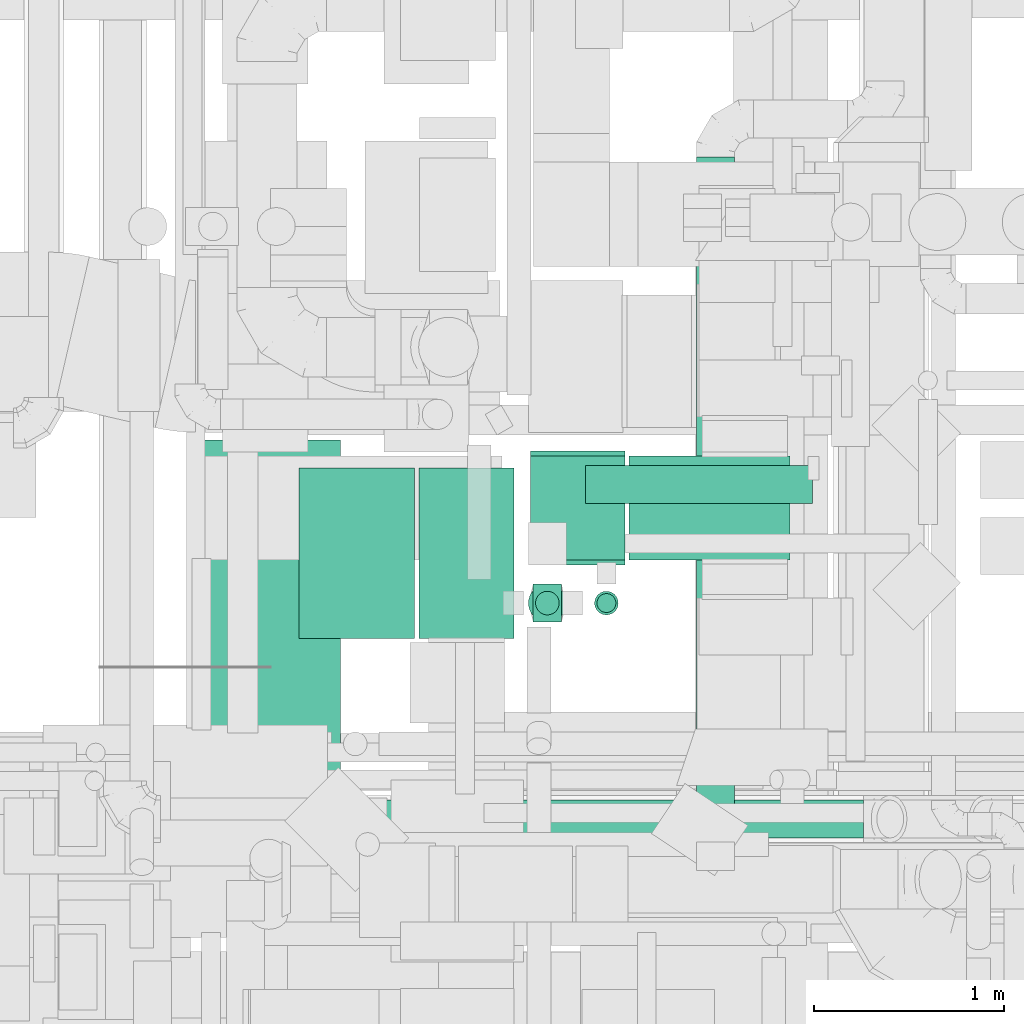
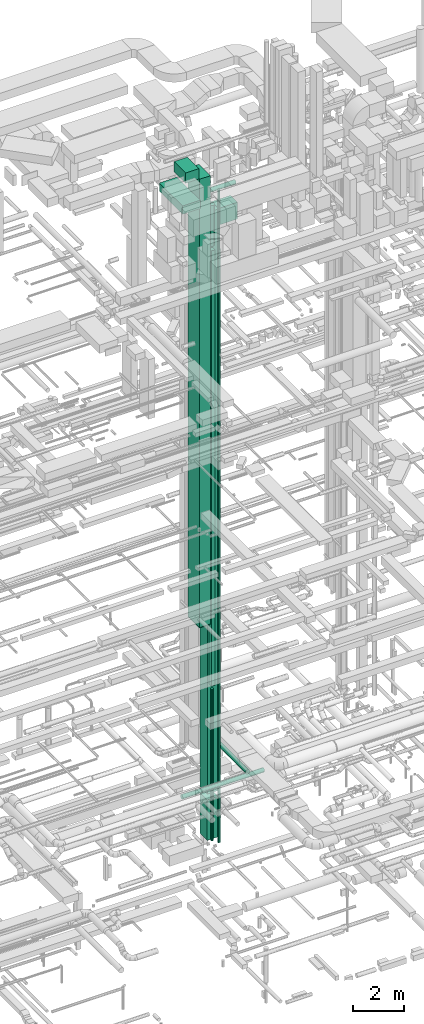
# One storey, part 41 of 337: 14 flow segments, 1 flow fitting.
"""IFC2X3 building model written with IfcOpenShell, lengths in millimetres."""

from ifc_helpers import new_model, entity, si_unit, converted_unit, derived_unit, direction, frame, origin, origin_2d_with_axis, place, context, subcontext, project, spatial, rectangle, circle, extrude, source, transform, mapped, material, type_object, type_shapes, element, save


model = new_model("IFC2X3")

# Units and contexts
model_context = context("Model", 3, precision=0.01, world=origin(), true_north=direction((6.12303176911189e-17, 1.0)))
body_context = subcontext(model_context, "Body", "Model", "MODEL_VIEW")
ifc_project = project(units=[si_unit("LENGTHUNIT", "METRE", prefix="MILLI"), si_unit("AREAUNIT", "SQUARE_METRE"), si_unit("VOLUMEUNIT", "CUBIC_METRE"), converted_unit("PLANEANGLEUNIT", "DEGREE", entity("IfcRatioMeasure", 0.0174532925199433), si_unit("PLANEANGLEUNIT", "RADIAN"), dimensions=[0, 0, 0, 0, 0, 0, 0]), si_unit("MASSUNIT", "GRAM", prefix="KILO"), derived_unit("MASSDENSITYUNIT", [(si_unit("MASSUNIT", "GRAM", prefix="KILO"), 1), (si_unit("LENGTHUNIT", "METRE"), -3)]), derived_unit("MOMENTOFINERTIAUNIT", [(si_unit("LENGTHUNIT", "METRE"), 4)]), si_unit("TIMEUNIT", "SECOND"), si_unit("FREQUENCYUNIT", "HERTZ"), si_unit("THERMODYNAMICTEMPERATUREUNIT", "DEGREE_CELSIUS"), derived_unit("THERMALTRANSMITTANCEUNIT", [(si_unit("MASSUNIT", "GRAM", prefix="KILO"), 1), (si_unit("THERMODYNAMICTEMPERATUREUNIT", "KELVIN"), -1), (si_unit("TIMEUNIT", "SECOND"), -3)]), derived_unit("VOLUMETRICFLOWRATEUNIT", [(si_unit("LENGTHUNIT", "METRE"), 3), (si_unit("TIMEUNIT", "SECOND"), -1)]), derived_unit("MASSFLOWRATEUNIT", [(si_unit("MASSUNIT", "GRAM", prefix="KILO"), 1), (si_unit("TIMEUNIT", "SECOND"), -1)]), derived_unit("ROTATIONALFREQUENCYUNIT", [(si_unit("TIMEUNIT", "SECOND"), -1)]), si_unit("ELECTRICCURRENTUNIT", "AMPERE"), si_unit("ELECTRICVOLTAGEUNIT", "VOLT"), si_unit("POWERUNIT", "WATT"), si_unit("FORCEUNIT", "NEWTON", prefix="KILO"), si_unit("ILLUMINANCEUNIT", "LUX"), si_unit("LUMINOUSFLUXUNIT", "LUMEN"), si_unit("LUMINOUSINTENSITYUNIT", "CANDELA"), derived_unit("USERDEFINED", [(si_unit("MASSUNIT", "GRAM", prefix="KILO"), -1), (si_unit("LENGTHUNIT", "METRE"), -2), (si_unit("TIMEUNIT", "SECOND"), 3), (si_unit("LUMINOUSFLUXUNIT", "LUMEN"), 1)]), derived_unit("LINEARVELOCITYUNIT", [(si_unit("LENGTHUNIT", "METRE"), 1), (si_unit("TIMEUNIT", "SECOND"), -1)]), si_unit("PRESSUREUNIT", "PASCAL"), derived_unit("USERDEFINED", [(si_unit("LENGTHUNIT", "METRE"), -2), (si_unit("MASSUNIT", "GRAM", prefix="KILO"), 1), (si_unit("TIMEUNIT", "SECOND"), -2)]), derived_unit("LINEARFORCEUNIT", [(si_unit("MASSUNIT", "GRAM", prefix="KILO"), 1), (si_unit("LENGTHUNIT", "METRE"), 1), (si_unit("TIMEUNIT", "SECOND"), -2), (si_unit("LENGTHUNIT", "METRE"), -1)]), derived_unit("PLANARFORCEUNIT", [(si_unit("MASSUNIT", "GRAM", prefix="KILO"), 1), (si_unit("LENGTHUNIT", "METRE"), 1), (si_unit("TIMEUNIT", "SECOND"), -2), (si_unit("LENGTHUNIT", "METRE"), -2)])], contexts=[model_context])

# Site, building, storey
site_placement = place(None, origin())
site = spatial("IfcSite", under=ifc_project, at=site_placement, CompositionType="ELEMENT")
building_placement = place(site_placement, origin())
building = spatial("IfcBuilding", under=site, at=building_placement, CompositionType="ELEMENT")
storey_placement = place(building_placement, origin())
storey = spatial("IfcBuildingStorey", under=building, at=storey_placement, CompositionType="ELEMENT", Elevation=0.0)

# Flow segments
duct_segment_type_1 = type_object("IfcDuctSegmentType", PredefinedType="NOTDEFINED")
flow_segment_1_placement = place(storey_placement, frame((44418.87, 10801.83, 9956.03)))
element("IfcFlowSegment", 1, at=flow_segment_1_placement, inside=storey, type_object=duct_segment_type_1, context=body_context, shape_type="SweptSolid", body=[
    extrude(rectangle(XDim=899.999999999999, YDim=499.999999999999, at=origin_2d_with_axis()), frame((250.0, 450.0, 0.0), z_axis=(0.0, 0.0, 1.0), x_axis=(0.0, -1.0, 0.0)), (0.0, 0.0, 1.0), 21478.9659417169),
])
flow_segment_2_placement = place(storey_placement, frame((45020.05, 10888.58, 6880.0)))
element("IfcFlowSegment", 2, at=flow_segment_2_placement, inside=storey, type_object=duct_segment_type_1, context=body_context, shape_type="SweptSolid", body=[
    extrude(rectangle(XDim=150.000000000001, YDim=200.0, at=origin_2d_with_axis()), frame((75.0, 100.0, 0.0)), (0.0, 0.0, 1.0), 20860.0),
])
flow_segment_3_placement = place(storey_placement, frame((43785.45, 10801.83, 31460.0)))
element("IfcFlowSegment", 3, at=flow_segment_3_placement, inside=storey, type_object=duct_segment_type_1, context=body_context, shape_type="SweptSolid", body=[
    extrude(rectangle(XDim=608.426980000926, YDim=900.000000000001, at=origin_2d_with_axis()), frame((304.21, 450.0, 0.0)), (0.0, 0.0, 1.0), 499.999999999999),
])
flow_segment_4_placement = place(storey_placement, frame((45524.94, 11214.6, 28600.0)))
element("IfcFlowSegment", 4, at=flow_segment_4_placement, inside=storey, type_object=duct_segment_type_1, context=body_context, shape_type="SweptSolid", body=[
    extrude(rectangle(XDim=848.580511700843, YDim=550.000000000001, at=origin_2d_with_axis()), frame((424.29, 275.0, 0.0), z_axis=(0.0, 0.0, 1.0), x_axis=(-1.0, 0.0, 0.0)), (0.0, 0.0, 1.0), 800.0),
])
flow_segment_5_placement = place(storey_placement, frame((43202.86, 10023.67, 30650.0)))
element("IfcFlowSegment", 5, at=flow_segment_5_placement, inside=storey, type_object=duct_segment_type_1, context=body_context, shape_type="SweptSolid", body=[
    extrude(rectangle(XDim=1826.18340999988, YDim=800.0, at=origin_2d_with_axis()), frame((400.0, 913.09, 0.0), z_axis=(0.0, 0.0, 1.0), x_axis=(0.0, 1.0, 0.0)), (0.0, 0.0, 1.0), 399.999999999996),
])
flow_segment_6_placement = place(storey_placement, frame((45004.94, 11189.6, 1536.11)))
element("IfcFlowSegment", 6, at=flow_segment_6_placement, inside=storey, type_object=duct_segment_type_1, context=body_context, shape_type="SweptSolid", body=[
    extrude(rectangle(XDim=600.000000000004, YDim=499.999999999999, at=origin_2d_with_axis()), frame((250.0, 300.0, 0.0), z_axis=(0.0, 0.0, 1.0), x_axis=(0.0, -1.0, 0.0)), (0.0, 0.0, 1.0), 27863.8898629147),
])
flow_segment_7_placement = place(storey_placement, frame((45004.94, 11214.6, -700.0)))
element("IfcFlowSegment", 7, at=flow_segment_7_placement, inside=storey, type_object=duct_segment_type_1, context=body_context, shape_type="SweptSolid", body=[
    extrude(rectangle(XDim=500.000000000008, YDim=550.000000000001, at=origin_2d_with_axis()), frame((250.0, 275.0, 0.0)), (0.0, 0.0, 1.0), 1936.1101370854),
])
duct_segment_type_2 = type_object("IfcDuctSegmentType", PredefinedType="NOTDEFINED")
flow_segment_8_placement = place(storey_placement, frame((45030.95, 10924.48, -575.0)))
element("IfcFlowSegment", 8, at=flow_segment_8_placement, inside=storey, type_object=duct_segment_type_2, context=body_context, shape_type="SweptSolid", body=[
    extrude(circle(Radius=62.5, at=origin_2d_with_axis()), frame((64.1, 64.1, 0.0), z_axis=(0.0, 0.0, 1.0), x_axis=(0.0, 1.0, 0.0)), (0.0, 0.0, 1.0), 7255.0),
])
flow_segment_9_placement = place(storey_placement, frame((45342.55, 10924.48, -775.0)))
element("IfcFlowSegment", 9, at=flow_segment_9_placement, inside=storey, type_object=duct_segment_type_2, context=body_context, shape_type="SweptSolid", body=[
    extrude(circle(Radius=62.5, at=origin_2d_with_axis()), frame((64.1, 64.1, 0.0), z_axis=(0.0, 0.0, 1.0), x_axis=(0.0, -1.0, 0.0)), (0.0, 0.0, 1.0), 28420.0),
])
flow_segment_10_placement = place(storey_placement, frame((45295.05, 11513.01, 29998.4)))
element("IfcFlowSegment", 10, at=flow_segment_10_placement, inside=storey, type_object=duct_segment_type_2, context=body_context, shape_type="SweptSolid", body=[
    extrude(circle(Radius=100.0, at=origin_2d_with_axis()), frame((0.0, 101.6, 101.6), z_axis=(1.0, 0.0, 0.0), x_axis=(0.0, 1.0, 0.0)), (0.0, 0.0, 1.0), 1199.42629020623),
])
flow_segment_11_placement = place(storey_placement, frame((44993.45, 10886.98, 27940.0)))
element("IfcFlowSegment", 11, at=flow_segment_11_placement, inside=storey, type_object=duct_segment_type_2, context=body_context, shape_type="SweptSolid", body=[
    extrude(circle(Radius=100.0, at=origin_2d_with_axis()), frame((101.6, 101.6, 0.0), z_axis=(0.0, 0.0, 1.0), x_axis=(-1.0, 0.0, 0.0)), (0.0, 0.0, 1.0), 1960.00000000001),
])
flow_segment_12_placement = place(storey_placement, frame((45355.05, 10936.98, 27670.0)))
element("IfcFlowSegment", 12, at=flow_segment_12_placement, inside=storey, type_object=duct_segment_type_2, context=body_context, shape_type="SweptSolid", body=[
    extrude(circle(Radius=50.0, at=origin_2d_with_axis()), frame((51.6, 51.6, 0.0)), (0.0, 0.0, 1.0), 2833.42267808452),
])
flow_segment_13_placement = place(storey_placement, frame((43055.12, 9748.4, 2798.4)))
element("IfcFlowSegment", 13, at=flow_segment_13_placement, inside=storey, type_object=duct_segment_type_2, context=body_context, shape_type="SweptSolid", body=[
    extrude(circle(Radius=100.0, at=origin_2d_with_axis()), frame((0.0, 101.6, 101.6), z_axis=(1.0, 0.0, 0.0), x_axis=(0.0, -1.0, 0.0)), (0.0, 0.0, 1.0), 3706.82348043657),
])
flow_segment_14_placement = place(storey_placement, frame((45880.59, 9727.45, 3048.4)))
element("IfcFlowSegment", 14, at=flow_segment_14_placement, inside=storey, type_object=duct_segment_type_2, context=body_context, shape_type="SweptSolid", body=[
    extrude(circle(Radius=100.0, at=origin_2d_with_axis()), frame((101.6, 0.0, 101.6), z_axis=(0.0, 1.0, 0.0), x_axis=(1.0, 0.0, 0.0)), (0.0, 0.0, 1.0), 3613.62253327498),
])

# Flow fitting
ifc_material = material()
duct_fitting_type = type_object("IfcDuctFittingType", PredefinedType="NOTDEFINED", material=ifc_material)
shared_shape = source(origin(), body_context, "Body", "SweptSolid", [
    extrude(rectangle(XDim=24.9999999999999, YDim=900.0, at=origin_2d_with_axis()), frame((12.5, 0.0, -250.0)), (0.0, 0.0, 1.0), 500.0),
])
type_shapes(duct_fitting_type, [shared_shape])
flow_fitting_placement = place(storey_placement, frame((44668.87, 11251.83, 9956.03), z_axis=(1.0, 0.0, 0.0), x_axis=(0.0, 0.0, -1.0)))
element("IfcFlowFitting", 15, at=flow_fitting_placement, inside=storey, type_object=duct_fitting_type, material=ifc_material, context=body_context, shape_type="MappedRepresentation", body=[
    mapped(shared_shape, transform((0.0, 0.0, 0.0), scale=1.0)),
])

save(model, "model.ifc")
